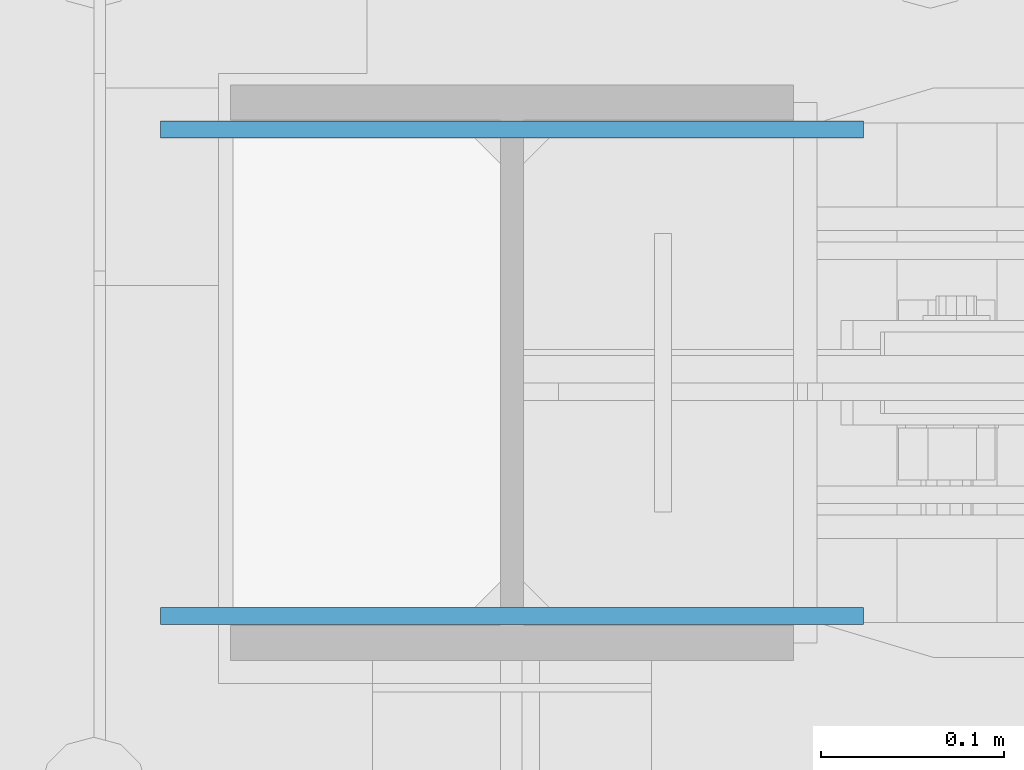
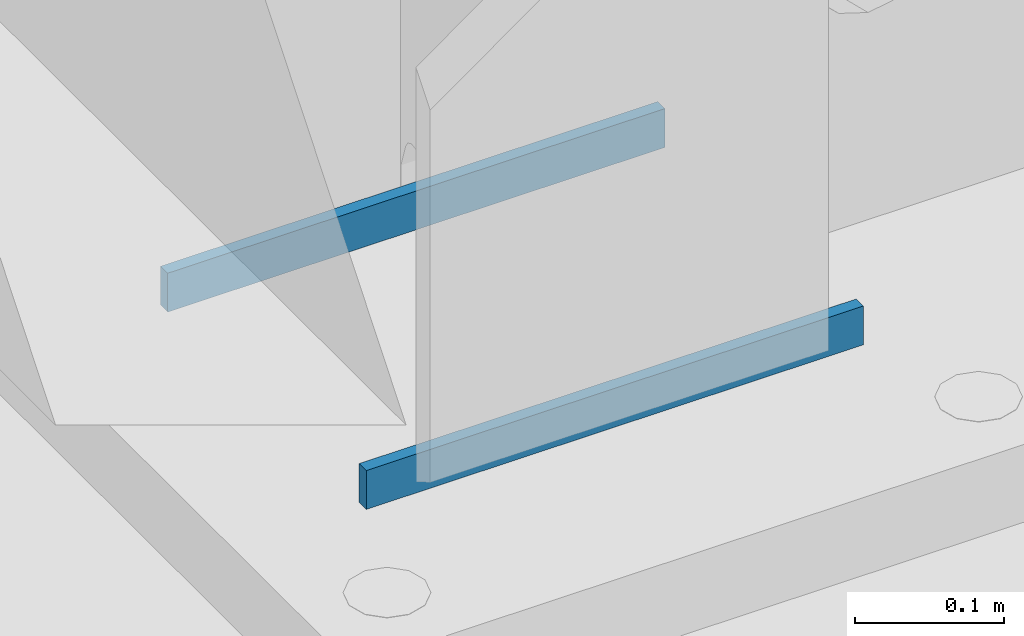
# One storey, part 504 of 1179: 2 columns, 1 element without a shape of its own.
"""IFC2X3 building model written with IfcOpenShell, lengths in millimetres."""

from ifc_helpers import new_model, si_unit, frame, origin_with_axes, place, context, subcontext, project, spatial, faceted_brep, material, type_object, element, aggregate, save


model = new_model("IFC2X3")

# Units and contexts
model_context = context("Model", 3, precision=1e-05, world=origin_with_axes())
body_context = subcontext(model_context, "Body", "Model", "MODEL_VIEW")
ifc_project = project(units=[si_unit("LENGTHUNIT", "METRE", prefix="MILLI"), si_unit("AREAUNIT", "SQUARE_METRE"), si_unit("VOLUMEUNIT", "CUBIC_METRE"), si_unit("MASSUNIT", "GRAM", prefix="KILO"), si_unit("TIMEUNIT", "SECOND"), si_unit("PLANEANGLEUNIT", "RADIAN"), si_unit("SOLIDANGLEUNIT", "STERADIAN"), si_unit("THERMODYNAMICTEMPERATUREUNIT", "DEGREE_CELSIUS"), si_unit("LUMINOUSINTENSITYUNIT", "LUMEN")], contexts=[model_context])

# Site, building, storey
site_placement = place(None, origin_with_axes())
site = spatial("IfcSite", under=ifc_project, at=site_placement, CompositionType="ELEMENT")
building_placement = place(site_placement, origin_with_axes())
building = spatial("IfcBuilding", under=site, at=building_placement, Name="Undefined", CompositionType="ELEMENT")
storey_placement = place(building_placement, origin_with_axes())
storey = spatial("IfcBuildingStorey", under=building, at=storey_placement, Name="Undefined", CompositionType="ELEMENT", Elevation=0.0)

# Assembly, columns
assembly_placement = place(storey_placement, origin_with_axes())
assembly = element("IfcElementAssembly", 1, at=assembly_placement, inside=storey, Name="COLUMN", AssemblyPlace="NOTDEFINED", PredefinedType="RIGID_FRAME")
ifc_material = material(Name="STEEL/A572-GR.50")
column_type = type_object("IfcColumnType", PredefinedType="NOTDEFINED")
column_1_placement = place(assembly_placement, frame((431.8, 41065.846875, -215.9), z_axis=(-1.0, 0.0, 0.0), x_axis=(0.0, 0.0, 1.0)))
column_1 = element("IfcColumn", 2, at=column_1_placement, type_object=column_type, material=ifc_material, Name="PLATE", context=body_context, shape_type="Brep", body=[
    faceted_brep([(0.0, 4.76249999999982, -192.087500000001), (0.0, 4.76249999999982, 192.0875), (31.75, 4.76249999999982, 192.0875), (31.75, 4.76249999999982, -192.087500000001), (0.0, -4.76249999999982, 192.0875), (31.75, -4.76249999999982, 192.0875), (0.0, -4.76249999999982, -192.087500000001), (31.75, -4.76249999999982, -192.087500000001)], [[[0, 1, 2, 3]], [[1, 4, 5, 2]], [[4, 6, 7, 5]], [[6, 0, 3, 7]], [[5, 7, 3, 2]], [[6, 4, 1, 0]]]),
])
column_2_placement = place(assembly_placement, frame((431.8, 41331.753125, -215.9), z_axis=(-1.0, 0.0, 0.0), x_axis=(0.0, 0.0, 1.0)))
column_2 = element("IfcColumn", 3, at=column_2_placement, type_object=column_type, material=ifc_material, Name="PLATE", context=body_context, shape_type="Brep", body=[
    faceted_brep([(0.0, 4.76249999999982, -192.087500000001), (0.0, 4.76249999999982, 192.0875), (31.75, 4.76249999999982, 192.0875), (31.75, 4.76249999999982, -192.087500000001), (0.0, -4.76249999999982, 192.0875), (31.75, -4.76249999999982, 192.0875), (0.0, -4.76249999999982, -192.087500000001), (31.75, -4.76249999999982, -192.087500000001)], [[[0, 1, 2, 3]], [[1, 4, 5, 2]], [[4, 6, 7, 5]], [[6, 0, 3, 7]], [[5, 7, 3, 2]], [[6, 4, 1, 0]]]),
])
aggregate(assembly, [column_1, column_2])

save(model, "model.ifc")
